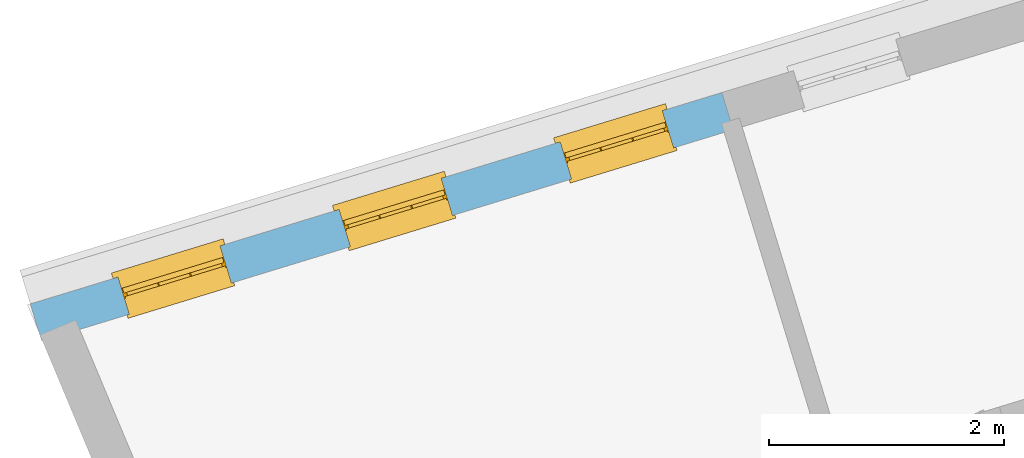
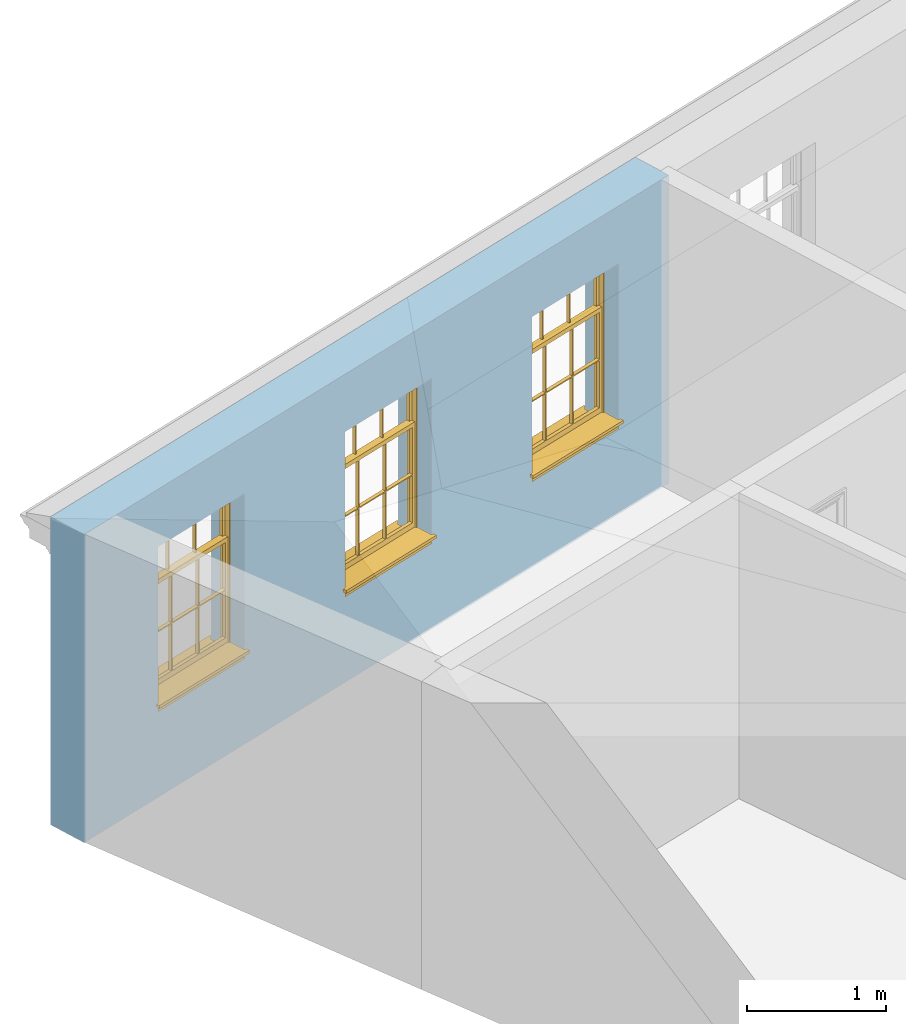
# One storey, part 4 of 10: 3 windows, 3 openings, plus 1 element that does not belong to this part.
"""IFC2X3 building model written with IfcOpenShell, lengths in metres."""

from ifc_helpers import new_model, si_unit, frame, origin, place, context, subcontext, project, spatial, polyline, outline, extrude, faceted_brep, material, layer, layer_set, layer_usage, element, fill, save


model = new_model("IFC2X3")

# Units and contexts
model_context = context("Model", 3, world=origin())
body_context = subcontext(model_context, "Body", "Model", "MODEL_VIEW")
ifc_project = project(units=[si_unit("PLANEANGLEUNIT", "RADIAN"), si_unit("MASSUNIT", "GRAM", prefix="KILO"), si_unit("FORCEUNIT", "NEWTON", prefix="KILO"), si_unit("LENGTHUNIT", "METRE")], contexts=[model_context])

# Site, building, storey
site_placement = place(None, origin())
site = spatial("IfcSite", under=ifc_project, at=site_placement, CompositionType="ELEMENT")
building_placement = place(None, origin())
building = spatial("IfcBuilding", under=site, at=building_placement, Name="Building plot-9", CompositionType="ELEMENT")
storey_placement = place(None, frame((0.0, 0.0, 4.3)))
storey = spatial("IfcBuildingStorey", under=building, at=storey_placement, Name="Floor 1", CompositionType="ELEMENT", Elevation=4.3)

# Wall, openings, windows
ifc_material = material(Name="Masonry")
ifc_layer = layer(ifc_material, 0.33, ventilated=False)
ifc_layer_set = layer_set([ifc_layer], Name="My Wall")
ifc_layer_usage = layer_usage(ifc_layer_set, "AXIS2", "NEGATIVE", 0.08)
wall_placement = place(storey_placement, origin())
wall = element("IfcWallStandardCase", 1, at=wall_placement, inside=storey, material=ifc_layer_usage, Name="exterior", context=body_context, shape_type="SweptSolid", body=[
    extrude(outline(polyline([(34.0704461659636, 21.7289389517045), (33.9739704454548, 22.0445216434864), (28.0907694978616, 20.2459881209039), (28.1872452183703, 19.930405429122), (34.0704461659636, 21.7289389517045)])), origin(), (0.0, 0.0, 1.0), 2.7),
])
opening_1_placement = place(storey_placement, frame((0.0, 0.0, 0.75)))
opening_1 = element("IfcOpeningElement", 2, at=opening_1_placement, cuts=wall, Name="Opening", ObjectType="Opening", context=body_context, shape_type="SweptSolid", body=[
    extrude(outline(polyline([(33.4684048438409, 21.8899668882661), (32.5981616634725, 21.6239277801966), (32.6946373839813, 21.3083450884147), (33.5648805643496, 21.5743841964841), (33.4684048438409, 21.8899668882661)])), origin(), (0.0, 0.0, 1.0), 1.445),
])
opening_2_placement = place(storey_placement, frame((0.0, 0.0, 0.75)))
opening_2 = element("IfcOpeningElement", 3, at=opening_2_placement, cuts=wall, Name="Opening", ObjectType="Opening", context=body_context, shape_type="SweptSolid", body=[
    extrude(outline(polyline([(31.5870304602446, 21.3148182697559), (30.7167872798763, 21.0487791616865), (30.813263000385, 20.7331964699045), (31.6835061807533, 20.999235577974), (31.5870304602446, 21.3148182697559)])), origin(), (0.0, 0.0, 1.0), 1.445),
])
opening_3_placement = place(storey_placement, frame((0.0, 0.0, 0.75)))
opening_3 = element("IfcOpeningElement", 4, at=opening_3_placement, cuts=wall, Name="Opening", ObjectType="Opening", context=body_context, shape_type="SweptSolid", body=[
    extrude(outline(polyline([(29.7056560766483, 20.7396696512458), (28.83541289628, 20.4736305431763), (28.9318886167887, 20.1580478513944), (29.8021317971571, 20.4240869594639), (29.7056560766483, 20.7396696512458)])), origin(), (0.0, 0.0, 1.0), 1.445),
])
window_1_placement = place(storey_placement, frame((33.5414925108929, 21.6508890914616, 0.75), z_axis=(0.0, 0.0, 1.0), x_axis=(-0.870243180368334, -0.266039108069478, 0.0)))
window_1 = element("IfcWindow", 5, at=window_1_placement, inside=storey, Name="bedroom outside window", OverallHeight=1.445, OverallWidth=0.91, context=body_context, shape_type="Brep", held_by="IfcProductRepresentation", body=[
    faceted_brep([(0.876875, -0.105, 0.999097), (0.876875, -0.105, 1.411875), (0.9, -0.105, 1.435), (0.033125, -0.105, 1.411875), (0.033125, -0.105, 0.999097), (0.01, -0.105, 1.435), (0.033125, -0.135, 1.411875), (0.01, -0.135, 1.435), (0.033125, -0.135, 0.999097), (0.876875, -0.135, 1.411875), (0.876875, -0.135, 0.999097), (0.9, -0.135, 1.435), (0.033125, -0.105, 0.960972), (0.01, -0.105, 0.960972), (0.033125, -0.105, 0.548195), (0.876875, -0.105, 0.960972), (0.876875, -0.105, 0.548195), (0.9, -0.105, 0.960972), (0.876875, -0.105, 0.538195), (0.876875, -0.105, 0.125417), (0.9, -0.105, 0.077167), (0.033125, -0.105, 0.125417), (0.033125, -0.105, 0.538195), (0.01, -0.105, 0.077167), (0.9, -0.135, 0.960972), (0.01, -0.135, 0.960972), (-0.0425, -0.25, 0.01), (-0.0425, -0.3, 0.001667), (0.0, -0.25, 0.01), (0.9525, -0.25, 0.01), (0.91, -0.25, 0.01), (0.9525, -0.3, 0.001667), (-0.02, 0.08, 0.077167), (0.0, 0.08, 0.077167), (-0.02, 0.11, 0.077167), (0.0, -0.06, 0.077167), (0.01, -0.06, 0.077167), (0.91, -0.06, 0.077167), (0.91, 0.08, 0.077167), (0.9, -0.06, 0.077167), (0.93, 0.08, 0.077167), (0.93, 0.11, 0.077167), (0.01, -0.105, 0.999097), (0.01, -0.075, 0.999097), (0.9, -0.105, 0.999097), (0.9, -0.075, 0.999097), (0.876875, -0.075, 0.125417), (0.876875, -0.075, 0.538195), (0.9, -0.075, 0.077167), (0.876875, -0.075, 0.548195), (0.876875, -0.075, 0.960972), (0.033125, -0.075, 0.125417), (0.01, -0.075, 0.077167), (0.033125, -0.075, 0.538195), (0.033125, -0.075, 0.960972), (0.033125, -0.075, 0.548195), (-0.02, 0.08, 0.052167), (-0.02, 0.11, 0.052167), (0.93, 0.11, 0.052167), (0.93, 0.08, 0.052167), (0.91, 0.08, 0.052167), (0.0, 0.08, 0.052167), (0.91, -0.15, 0.026667), (0.0, -0.15, 0.026667), (-0.0425, -0.3, -0.123333), (0.9525, -0.3, -0.123333), (-0.0425, -0.25, -0.123333), (0.9525, -0.25, -0.123333), (0.01, -0.06, 1.435), (0.9, -0.06, 1.435), (0.0, -0.06, 1.445), (0.91, -0.06, 1.445), (0.01, -0.15, 0.077167), (0.9, -0.15, 0.077167), (0.592292, -0.105, 0.125417), (0.592292, -0.075, 0.125417), (0.317708, -0.075, 0.125417), (0.317708, -0.105, 0.125417), (0.592292, -0.105, 0.548195), (0.317708, -0.105, 0.548195), (0.317708, -0.105, 0.538195), (0.592292, -0.105, 0.538195), (0.592292, -0.075, 0.548195), (0.317708, -0.075, 0.548195), (0.602292, -0.075, 0.548195), (0.602292, -0.105, 0.548195), (0.317708, -0.075, 0.538195), (0.307708, -0.075, 0.125417), (0.307708, -0.075, 0.538195), (0.602292, -0.075, 0.538195), (0.602292, -0.075, 0.125417), (0.592292, -0.075, 0.538195), (0.307708, -0.075, 0.548195), (0.317708, -0.075, 0.960972), (0.307708, -0.075, 0.960972), (0.602292, -0.075, 0.960972), (0.592292, -0.075, 0.960972), (0.307708, -0.105, 0.538195), (0.307708, -0.105, 0.125417), (0.307708, -0.105, 0.548195), (0.307708, -0.105, 0.960972), (0.592292, -0.105, 0.960972), (0.317708, -0.105, 0.960972), (0.602292, -0.105, 0.960972), (0.602292, -0.105, 0.538195), (0.602292, -0.105, 0.125417), (0.317708, -0.135, 1.411875), (0.307708, -0.135, 1.411875), (0.307708, -0.135, 0.999097), (0.317708, -0.135, 0.999097), (0.602292, -0.135, 1.411875), (0.592292, -0.135, 1.411875), (0.592292, -0.135, 0.999097), (0.602292, -0.135, 0.999097), (0.317708, -0.105, 0.999097), (0.307708, -0.105, 0.999097), (0.307708, -0.105, 1.411875), (0.317708, -0.105, 1.411875), (0.602292, -0.105, 0.999097), (0.592292, -0.105, 0.999097), (0.592292, -0.105, 1.411875), (0.602292, -0.105, 1.411875), (0.91, -0.15, 1.445), (0.9, -0.15, 1.435), (0.01, -0.15, 1.435), (0.0, -0.15, 1.445), (0.91, -0.25, 0.0), (0.0, -0.25, 0.0), (0.91, 0.08, 0.0), (0.0, 0.08, 0.0)], [[[0, 1, 2]], [[3, 4, 5]], [[6, 7, 8]], [[9, 10, 11]], [[12, 13, 14]], [[15, 16, 17]], [[18, 19, 20]], [[21, 22, 23]], [[24, 15, 17]], [[13, 12, 25]], [[26, 27, 28]], [[29, 30, 31]], [[32, 33, 34]], [[35, 36, 33]], [[37, 38, 39]], [[40, 41, 38]], [[42, 4, 43]], [[44, 45, 0]], [[46, 47, 48]], [[49, 50, 45]], [[51, 52, 53]], [[54, 55, 43]], [[38, 33, 36, 39]], [[41, 34, 33, 38]], [[56, 32, 34, 57]], [[57, 34, 41, 58]], [[58, 41, 40, 59]], [[57, 58, 60, 61]], [[52, 48, 39, 36]], [[62, 63, 28, 30]], [[27, 31, 30, 28]], [[27, 64, 65, 31]], [[66, 67, 65, 64]], [[2, 5, 68, 69]], [[68, 70, 71, 69]], [[20, 23, 72, 73]], [[73, 72, 63, 62]], [[74, 75, 76, 77]], [[78, 79, 80, 81]], [[78, 82, 83, 79]], [[16, 49, 84, 85]], [[86, 76, 87, 88]], [[89, 90, 75, 91]], [[92, 88, 53, 55]], [[82, 91, 86, 83]], [[93, 83, 92, 94]], [[95, 84, 82, 96]], [[89, 84, 49, 47]], [[97, 88, 87, 98]], [[22, 53, 88, 97]], [[81, 91, 75, 74]], [[80, 86, 91, 81]], [[77, 76, 86, 80]], [[99, 92, 55, 14]], [[100, 94, 92, 99]], [[101, 96, 82, 78]], [[79, 83, 93, 102]], [[85, 84, 95, 103]], [[104, 89, 47, 18]], [[105, 90, 89, 104]], [[104, 18, 16, 85]], [[80, 97, 98, 77]], [[104, 81, 74, 105]], [[103, 101, 78, 85]], [[99, 14, 22, 97]], [[102, 100, 99, 79]], [[106, 107, 108, 109]], [[110, 111, 112, 113]], [[114, 115, 116, 117]], [[118, 119, 120, 121]], [[107, 116, 115, 108]], [[111, 120, 119, 112]], [[109, 114, 117, 106]], [[113, 118, 121, 110]], [[85, 78, 81, 104]], [[84, 89, 91, 82]], [[83, 86, 88, 92]], [[79, 99, 97, 80]], [[109, 112, 119, 114]], [[102, 93, 96, 101]], [[106, 117, 120, 111]], [[98, 87, 51, 21]], [[6, 3, 116, 107]], [[110, 121, 1, 9]], [[19, 46, 90, 105]], [[26, 66, 64, 27]], [[29, 31, 65, 67]], [[25, 24, 112, 109]], [[11, 7, 106, 111]], [[75, 48, 52, 76]], [[43, 45, 96, 93]], [[45, 43, 114, 119]], [[5, 2, 120, 117]], [[24, 25, 102, 101]], [[42, 5, 4]], [[2, 44, 0]], [[49, 45, 48, 47]], [[52, 43, 55, 53]], [[14, 13, 23, 22]], [[20, 17, 16, 18]], [[24, 11, 10]], [[25, 8, 7]], [[8, 4, 3, 6]], [[9, 1, 0, 10]], [[15, 50, 49, 16]], [[18, 47, 46, 19]], [[21, 51, 53, 22]], [[14, 55, 54, 12]], [[44, 2, 69, 45]], [[68, 5, 42, 43]], [[36, 35, 70, 68]], [[39, 69, 71, 37]], [[62, 122, 123, 73]], [[63, 72, 124, 125]], [[8, 108, 115, 4]], [[113, 10, 0, 118]], [[94, 100, 12, 54]], [[17, 20, 73, 24]], [[72, 23, 13, 25]], [[52, 36, 68, 43]], [[69, 39, 48, 45]], [[11, 24, 73, 123]], [[7, 124, 72, 25]], [[23, 77, 98]], [[98, 21, 23]], [[105, 74, 20]], [[20, 19, 105]], [[20, 74, 77, 23]], [[113, 112, 24]], [[24, 10, 113]], [[25, 109, 108]], [[108, 8, 25]], [[110, 9, 11]], [[11, 111, 110]], [[7, 6, 107]], [[107, 106, 7]], [[5, 117, 116]], [[116, 3, 5]], [[121, 120, 2]], [[2, 1, 121]], [[11, 123, 124, 7]], [[122, 125, 124, 123]], [[43, 93, 94]], [[94, 54, 43]], [[96, 45, 95]], [[50, 95, 45]], [[15, 103, 95, 50]], [[48, 75, 90]], [[90, 46, 48]], [[87, 76, 52]], [[52, 51, 87]], [[103, 15, 24]], [[24, 101, 103]], [[100, 102, 25]], [[25, 12, 100]], [[115, 114, 43]], [[43, 4, 115]], [[118, 0, 45]], [[45, 119, 118]], [[71, 70, 125, 122]], [[70, 35, 63, 125]], [[122, 62, 37, 71]], [[126, 67, 66, 127]], [[60, 58, 59]], [[38, 60, 59, 40]], [[61, 56, 57]], [[32, 56, 61, 33]], [[61, 60, 128, 129]], [[62, 60, 38, 37]], [[126, 128, 60, 62]], [[33, 61, 63, 35]], [[61, 129, 127, 63]], [[128, 126, 127, 129]], [[28, 127, 66, 26]], [[63, 127, 28]], [[29, 67, 126, 30]], [[30, 126, 62]]]),
])
fill(opening_1, window_1)
window_2_placement = place(storey_placement, frame((31.6601181272967, 21.0757404729514, 0.75), z_axis=(0.0, 0.0, 1.0), x_axis=(-0.870243180368337, -0.266039108069474, 0.0)))
window_2 = element("IfcWindow", 6, at=window_2_placement, inside=storey, Name="bedroom outside window", OverallHeight=1.445, OverallWidth=0.91, context=body_context, shape_type="Brep", held_by="IfcProductRepresentation", body=[
    faceted_brep([(0.876875, -0.105, 0.999097), (0.876875, -0.105, 1.411875), (0.9, -0.105, 1.435), (0.033125, -0.105, 1.411875), (0.033125, -0.105, 0.999097), (0.01, -0.105, 1.435), (0.033125, -0.135, 1.411875), (0.01, -0.135, 1.435), (0.033125, -0.135, 0.999097), (0.876875, -0.135, 1.411875), (0.876875, -0.135, 0.999097), (0.9, -0.135, 1.435), (0.033125, -0.105, 0.960972), (0.01, -0.105, 0.960972), (0.033125, -0.105, 0.548195), (0.876875, -0.105, 0.960972), (0.876875, -0.105, 0.548195), (0.9, -0.105, 0.960972), (0.876875, -0.105, 0.538195), (0.876875, -0.105, 0.125417), (0.9, -0.105, 0.077167), (0.033125, -0.105, 0.125417), (0.033125, -0.105, 0.538195), (0.01, -0.105, 0.077167), (0.9, -0.135, 0.960972), (0.01, -0.135, 0.960972), (-0.0425, -0.25, 0.01), (-0.0425, -0.3, 0.001667), (0.0, -0.25, 0.01), (0.9525, -0.25, 0.01), (0.91, -0.25, 0.01), (0.9525, -0.3, 0.001667), (-0.02, 0.08, 0.077167), (0.0, 0.08, 0.077167), (-0.02, 0.11, 0.077167), (0.0, -0.06, 0.077167), (0.01, -0.06, 0.077167), (0.91, -0.06, 0.077167), (0.91, 0.08, 0.077167), (0.9, -0.06, 0.077167), (0.93, 0.08, 0.077167), (0.93, 0.11, 0.077167), (0.01, -0.105, 0.999097), (0.01, -0.075, 0.999097), (0.9, -0.105, 0.999097), (0.9, -0.075, 0.999097), (0.876875, -0.075, 0.125417), (0.876875, -0.075, 0.538195), (0.9, -0.075, 0.077167), (0.876875, -0.075, 0.548195), (0.876875, -0.075, 0.960972), (0.033125, -0.075, 0.125417), (0.01, -0.075, 0.077167), (0.033125, -0.075, 0.538195), (0.033125, -0.075, 0.960972), (0.033125, -0.075, 0.548195), (-0.02, 0.08, 0.052167), (-0.02, 0.11, 0.052167), (0.93, 0.11, 0.052167), (0.93, 0.08, 0.052167), (0.91, 0.08, 0.052167), (0.0, 0.08, 0.052167), (0.91, -0.15, 0.026667), (0.0, -0.15, 0.026667), (-0.0425, -0.3, -0.123333), (0.9525, -0.3, -0.123333), (-0.0425, -0.25, -0.123333), (0.9525, -0.25, -0.123333), (0.01, -0.06, 1.435), (0.9, -0.06, 1.435), (0.0, -0.06, 1.445), (0.91, -0.06, 1.445), (0.01, -0.15, 0.077167), (0.9, -0.15, 0.077167), (0.592292, -0.105, 0.125417), (0.592292, -0.075, 0.125417), (0.317708, -0.075, 0.125417), (0.317708, -0.105, 0.125417), (0.592292, -0.105, 0.548195), (0.317708, -0.105, 0.548195), (0.317708, -0.105, 0.538195), (0.592292, -0.105, 0.538195), (0.592292, -0.075, 0.548195), (0.317708, -0.075, 0.548195), (0.602292, -0.075, 0.548195), (0.602292, -0.105, 0.548195), (0.317708, -0.075, 0.538195), (0.307708, -0.075, 0.125417), (0.307708, -0.075, 0.538195), (0.602292, -0.075, 0.538195), (0.602292, -0.075, 0.125417), (0.592292, -0.075, 0.538195), (0.307708, -0.075, 0.548195), (0.317708, -0.075, 0.960972), (0.307708, -0.075, 0.960972), (0.602292, -0.075, 0.960972), (0.592292, -0.075, 0.960972), (0.307708, -0.105, 0.538195), (0.307708, -0.105, 0.125417), (0.307708, -0.105, 0.548195), (0.307708, -0.105, 0.960972), (0.592292, -0.105, 0.960972), (0.317708, -0.105, 0.960972), (0.602292, -0.105, 0.960972), (0.602292, -0.105, 0.538195), (0.602292, -0.105, 0.125417), (0.317708, -0.135, 1.411875), (0.307708, -0.135, 1.411875), (0.307708, -0.135, 0.999097), (0.317708, -0.135, 0.999097), (0.602292, -0.135, 1.411875), (0.592292, -0.135, 1.411875), (0.592292, -0.135, 0.999097), (0.602292, -0.135, 0.999097), (0.317708, -0.105, 0.999097), (0.307708, -0.105, 0.999097), (0.307708, -0.105, 1.411875), (0.317708, -0.105, 1.411875), (0.602292, -0.105, 0.999097), (0.592292, -0.105, 0.999097), (0.592292, -0.105, 1.411875), (0.602292, -0.105, 1.411875), (0.91, -0.15, 1.445), (0.9, -0.15, 1.435), (0.01, -0.15, 1.435), (0.0, -0.15, 1.445), (0.91, -0.25, 0.0), (0.0, -0.25, 0.0), (0.91, 0.08, 0.0), (0.0, 0.08, 0.0)], [[[0, 1, 2]], [[3, 4, 5]], [[6, 7, 8]], [[9, 10, 11]], [[12, 13, 14]], [[15, 16, 17]], [[18, 19, 20]], [[21, 22, 23]], [[24, 15, 17]], [[13, 12, 25]], [[26, 27, 28]], [[29, 30, 31]], [[32, 33, 34]], [[35, 36, 33]], [[37, 38, 39]], [[40, 41, 38]], [[42, 4, 43]], [[44, 45, 0]], [[46, 47, 48]], [[49, 50, 45]], [[51, 52, 53]], [[54, 55, 43]], [[38, 33, 36, 39]], [[41, 34, 33, 38]], [[56, 32, 34, 57]], [[57, 34, 41, 58]], [[58, 41, 40, 59]], [[57, 58, 60, 61]], [[52, 48, 39, 36]], [[62, 63, 28, 30]], [[27, 31, 30, 28]], [[27, 64, 65, 31]], [[66, 67, 65, 64]], [[2, 5, 68, 69]], [[68, 70, 71, 69]], [[20, 23, 72, 73]], [[73, 72, 63, 62]], [[74, 75, 76, 77]], [[78, 79, 80, 81]], [[78, 82, 83, 79]], [[16, 49, 84, 85]], [[86, 76, 87, 88]], [[89, 90, 75, 91]], [[92, 88, 53, 55]], [[82, 91, 86, 83]], [[93, 83, 92, 94]], [[95, 84, 82, 96]], [[89, 84, 49, 47]], [[97, 88, 87, 98]], [[22, 53, 88, 97]], [[81, 91, 75, 74]], [[80, 86, 91, 81]], [[77, 76, 86, 80]], [[99, 92, 55, 14]], [[100, 94, 92, 99]], [[101, 96, 82, 78]], [[79, 83, 93, 102]], [[85, 84, 95, 103]], [[104, 89, 47, 18]], [[105, 90, 89, 104]], [[104, 18, 16, 85]], [[80, 97, 98, 77]], [[104, 81, 74, 105]], [[103, 101, 78, 85]], [[99, 14, 22, 97]], [[102, 100, 99, 79]], [[106, 107, 108, 109]], [[110, 111, 112, 113]], [[114, 115, 116, 117]], [[118, 119, 120, 121]], [[107, 116, 115, 108]], [[111, 120, 119, 112]], [[109, 114, 117, 106]], [[113, 118, 121, 110]], [[85, 78, 81, 104]], [[84, 89, 91, 82]], [[83, 86, 88, 92]], [[79, 99, 97, 80]], [[109, 112, 119, 114]], [[102, 93, 96, 101]], [[106, 117, 120, 111]], [[98, 87, 51, 21]], [[6, 3, 116, 107]], [[110, 121, 1, 9]], [[19, 46, 90, 105]], [[26, 66, 64, 27]], [[29, 31, 65, 67]], [[25, 24, 112, 109]], [[11, 7, 106, 111]], [[75, 48, 52, 76]], [[43, 45, 96, 93]], [[45, 43, 114, 119]], [[5, 2, 120, 117]], [[24, 25, 102, 101]], [[42, 5, 4]], [[2, 44, 0]], [[49, 45, 48, 47]], [[52, 43, 55, 53]], [[14, 13, 23, 22]], [[20, 17, 16, 18]], [[24, 11, 10]], [[25, 8, 7]], [[8, 4, 3, 6]], [[9, 1, 0, 10]], [[15, 50, 49, 16]], [[18, 47, 46, 19]], [[21, 51, 53, 22]], [[14, 55, 54, 12]], [[44, 2, 69, 45]], [[68, 5, 42, 43]], [[36, 35, 70, 68]], [[39, 69, 71, 37]], [[62, 122, 123, 73]], [[63, 72, 124, 125]], [[8, 108, 115, 4]], [[113, 10, 0, 118]], [[94, 100, 12, 54]], [[17, 20, 73, 24]], [[72, 23, 13, 25]], [[52, 36, 68, 43]], [[69, 39, 48, 45]], [[11, 24, 73, 123]], [[7, 124, 72, 25]], [[23, 77, 98]], [[98, 21, 23]], [[105, 74, 20]], [[20, 19, 105]], [[20, 74, 77, 23]], [[113, 112, 24]], [[24, 10, 113]], [[25, 109, 108]], [[108, 8, 25]], [[110, 9, 11]], [[11, 111, 110]], [[7, 6, 107]], [[107, 106, 7]], [[5, 117, 116]], [[116, 3, 5]], [[121, 120, 2]], [[2, 1, 121]], [[11, 123, 124, 7]], [[122, 125, 124, 123]], [[43, 93, 94]], [[94, 54, 43]], [[96, 45, 95]], [[50, 95, 45]], [[15, 103, 95, 50]], [[48, 75, 90]], [[90, 46, 48]], [[87, 76, 52]], [[52, 51, 87]], [[103, 15, 24]], [[24, 101, 103]], [[100, 102, 25]], [[25, 12, 100]], [[115, 114, 43]], [[43, 4, 115]], [[118, 0, 45]], [[45, 119, 118]], [[71, 70, 125, 122]], [[70, 35, 63, 125]], [[122, 62, 37, 71]], [[126, 67, 66, 127]], [[60, 58, 59]], [[38, 60, 59, 40]], [[61, 56, 57]], [[32, 56, 61, 33]], [[61, 60, 128, 129]], [[62, 60, 38, 37]], [[126, 128, 60, 62]], [[33, 61, 63, 35]], [[61, 129, 127, 63]], [[128, 126, 127, 129]], [[28, 127, 66, 26]], [[63, 127, 28]], [[29, 67, 126, 30]], [[30, 126, 62]]]),
])
fill(opening_2, window_2)
window_3_placement = place(storey_placement, frame((29.7787437437004, 20.5005918544413, 0.75), z_axis=(0.0, 0.0, 1.0), x_axis=(-0.870243180368337, -0.266039108069478, 0.0)))
window_3 = element("IfcWindow", 7, at=window_3_placement, inside=storey, Name="bedroom outside window", OverallHeight=1.445, OverallWidth=0.91, context=body_context, shape_type="Brep", held_by="IfcProductRepresentation", body=[
    faceted_brep([(0.876875, -0.105, 0.999097), (0.876875, -0.105, 1.411875), (0.9, -0.105, 1.435), (0.033125, -0.105, 1.411875), (0.033125, -0.105, 0.999097), (0.01, -0.105, 1.435), (0.033125, -0.135, 1.411875), (0.01, -0.135, 1.435), (0.033125, -0.135, 0.999097), (0.876875, -0.135, 1.411875), (0.876875, -0.135, 0.999097), (0.9, -0.135, 1.435), (0.033125, -0.105, 0.960972), (0.01, -0.105, 0.960972), (0.033125, -0.105, 0.548195), (0.876875, -0.105, 0.960972), (0.876875, -0.105, 0.548195), (0.9, -0.105, 0.960972), (0.876875, -0.105, 0.538195), (0.876875, -0.105, 0.125417), (0.9, -0.105, 0.077167), (0.033125, -0.105, 0.125417), (0.033125, -0.105, 0.538195), (0.01, -0.105, 0.077167), (0.9, -0.135, 0.960972), (0.01, -0.135, 0.960972), (-0.0425, -0.25, 0.01), (-0.0425, -0.3, 0.001667), (0.0, -0.25, 0.01), (0.9525, -0.25, 0.01), (0.91, -0.25, 0.01), (0.9525, -0.3, 0.001667), (-0.02, 0.08, 0.077167), (0.0, 0.08, 0.077167), (-0.02, 0.11, 0.077167), (0.0, -0.06, 0.077167), (0.01, -0.06, 0.077167), (0.91, -0.06, 0.077167), (0.91, 0.08, 0.077167), (0.9, -0.06, 0.077167), (0.93, 0.08, 0.077167), (0.93, 0.11, 0.077167), (0.01, -0.105, 0.999097), (0.01, -0.075, 0.999097), (0.9, -0.105, 0.999097), (0.9, -0.075, 0.999097), (0.876875, -0.075, 0.125417), (0.876875, -0.075, 0.538195), (0.9, -0.075, 0.077167), (0.876875, -0.075, 0.548195), (0.876875, -0.075, 0.960972), (0.033125, -0.075, 0.125417), (0.01, -0.075, 0.077167), (0.033125, -0.075, 0.538195), (0.033125, -0.075, 0.960972), (0.033125, -0.075, 0.548195), (-0.02, 0.08, 0.052167), (-0.02, 0.11, 0.052167), (0.93, 0.11, 0.052167), (0.93, 0.08, 0.052167), (0.91, 0.08, 0.052167), (0.0, 0.08, 0.052167), (0.91, -0.15, 0.026667), (0.0, -0.15, 0.026667), (-0.0425, -0.3, -0.123333), (0.9525, -0.3, -0.123333), (-0.0425, -0.25, -0.123333), (0.9525, -0.25, -0.123333), (0.01, -0.06, 1.435), (0.9, -0.06, 1.435), (0.0, -0.06, 1.445), (0.91, -0.06, 1.445), (0.01, -0.15, 0.077167), (0.9, -0.15, 0.077167), (0.592292, -0.105, 0.125417), (0.592292, -0.075, 0.125417), (0.317708, -0.075, 0.125417), (0.317708, -0.105, 0.125417), (0.592292, -0.105, 0.548195), (0.317708, -0.105, 0.548195), (0.317708, -0.105, 0.538195), (0.592292, -0.105, 0.538195), (0.592292, -0.075, 0.548195), (0.317708, -0.075, 0.548195), (0.602292, -0.075, 0.548195), (0.602292, -0.105, 0.548195), (0.317708, -0.075, 0.538195), (0.307708, -0.075, 0.125417), (0.307708, -0.075, 0.538195), (0.602292, -0.075, 0.538195), (0.602292, -0.075, 0.125417), (0.592292, -0.075, 0.538195), (0.307708, -0.075, 0.548195), (0.317708, -0.075, 0.960972), (0.307708, -0.075, 0.960972), (0.602292, -0.075, 0.960972), (0.592292, -0.075, 0.960972), (0.307708, -0.105, 0.538195), (0.307708, -0.105, 0.125417), (0.307708, -0.105, 0.548195), (0.307708, -0.105, 0.960972), (0.592292, -0.105, 0.960972), (0.317708, -0.105, 0.960972), (0.602292, -0.105, 0.960972), (0.602292, -0.105, 0.538195), (0.602292, -0.105, 0.125417), (0.317708, -0.135, 1.411875), (0.307708, -0.135, 1.411875), (0.307708, -0.135, 0.999097), (0.317708, -0.135, 0.999097), (0.602292, -0.135, 1.411875), (0.592292, -0.135, 1.411875), (0.592292, -0.135, 0.999097), (0.602292, -0.135, 0.999097), (0.317708, -0.105, 0.999097), (0.307708, -0.105, 0.999097), (0.307708, -0.105, 1.411875), (0.317708, -0.105, 1.411875), (0.602292, -0.105, 0.999097), (0.592292, -0.105, 0.999097), (0.592292, -0.105, 1.411875), (0.602292, -0.105, 1.411875), (0.91, -0.15, 1.445), (0.9, -0.15, 1.435), (0.01, -0.15, 1.435), (0.0, -0.15, 1.445), (0.91, -0.25, 0.0), (0.0, -0.25, 0.0), (0.91, 0.08, 0.0), (0.0, 0.08, 0.0)], [[[0, 1, 2]], [[3, 4, 5]], [[6, 7, 8]], [[9, 10, 11]], [[12, 13, 14]], [[15, 16, 17]], [[18, 19, 20]], [[21, 22, 23]], [[24, 15, 17]], [[13, 12, 25]], [[26, 27, 28]], [[29, 30, 31]], [[32, 33, 34]], [[35, 36, 33]], [[37, 38, 39]], [[40, 41, 38]], [[42, 4, 43]], [[44, 45, 0]], [[46, 47, 48]], [[49, 50, 45]], [[51, 52, 53]], [[54, 55, 43]], [[38, 33, 36, 39]], [[41, 34, 33, 38]], [[56, 32, 34, 57]], [[57, 34, 41, 58]], [[58, 41, 40, 59]], [[57, 58, 60, 61]], [[52, 48, 39, 36]], [[62, 63, 28, 30]], [[27, 31, 30, 28]], [[27, 64, 65, 31]], [[66, 67, 65, 64]], [[2, 5, 68, 69]], [[68, 70, 71, 69]], [[20, 23, 72, 73]], [[73, 72, 63, 62]], [[74, 75, 76, 77]], [[78, 79, 80, 81]], [[78, 82, 83, 79]], [[16, 49, 84, 85]], [[86, 76, 87, 88]], [[89, 90, 75, 91]], [[92, 88, 53, 55]], [[82, 91, 86, 83]], [[93, 83, 92, 94]], [[95, 84, 82, 96]], [[89, 84, 49, 47]], [[97, 88, 87, 98]], [[22, 53, 88, 97]], [[81, 91, 75, 74]], [[80, 86, 91, 81]], [[77, 76, 86, 80]], [[99, 92, 55, 14]], [[100, 94, 92, 99]], [[101, 96, 82, 78]], [[79, 83, 93, 102]], [[85, 84, 95, 103]], [[104, 89, 47, 18]], [[105, 90, 89, 104]], [[104, 18, 16, 85]], [[80, 97, 98, 77]], [[104, 81, 74, 105]], [[103, 101, 78, 85]], [[99, 14, 22, 97]], [[102, 100, 99, 79]], [[106, 107, 108, 109]], [[110, 111, 112, 113]], [[114, 115, 116, 117]], [[118, 119, 120, 121]], [[107, 116, 115, 108]], [[111, 120, 119, 112]], [[109, 114, 117, 106]], [[113, 118, 121, 110]], [[85, 78, 81, 104]], [[84, 89, 91, 82]], [[83, 86, 88, 92]], [[79, 99, 97, 80]], [[109, 112, 119, 114]], [[102, 93, 96, 101]], [[106, 117, 120, 111]], [[98, 87, 51, 21]], [[6, 3, 116, 107]], [[110, 121, 1, 9]], [[19, 46, 90, 105]], [[26, 66, 64, 27]], [[29, 31, 65, 67]], [[25, 24, 112, 109]], [[11, 7, 106, 111]], [[75, 48, 52, 76]], [[43, 45, 96, 93]], [[45, 43, 114, 119]], [[5, 2, 120, 117]], [[24, 25, 102, 101]], [[42, 5, 4]], [[2, 44, 0]], [[49, 45, 48, 47]], [[52, 43, 55, 53]], [[14, 13, 23, 22]], [[20, 17, 16, 18]], [[24, 11, 10]], [[25, 8, 7]], [[8, 4, 3, 6]], [[9, 1, 0, 10]], [[15, 50, 49, 16]], [[18, 47, 46, 19]], [[21, 51, 53, 22]], [[14, 55, 54, 12]], [[44, 2, 69, 45]], [[68, 5, 42, 43]], [[36, 35, 70, 68]], [[39, 69, 71, 37]], [[62, 122, 123, 73]], [[63, 72, 124, 125]], [[8, 108, 115, 4]], [[113, 10, 0, 118]], [[94, 100, 12, 54]], [[17, 20, 73, 24]], [[72, 23, 13, 25]], [[52, 36, 68, 43]], [[69, 39, 48, 45]], [[11, 24, 73, 123]], [[7, 124, 72, 25]], [[23, 77, 98]], [[98, 21, 23]], [[105, 74, 20]], [[20, 19, 105]], [[20, 74, 77, 23]], [[113, 112, 24]], [[24, 10, 113]], [[25, 109, 108]], [[108, 8, 25]], [[110, 9, 11]], [[11, 111, 110]], [[7, 6, 107]], [[107, 106, 7]], [[5, 117, 116]], [[116, 3, 5]], [[121, 120, 2]], [[2, 1, 121]], [[11, 123, 124, 7]], [[122, 125, 124, 123]], [[43, 93, 94]], [[94, 54, 43]], [[96, 45, 95]], [[50, 95, 45]], [[15, 103, 95, 50]], [[48, 75, 90]], [[90, 46, 48]], [[87, 76, 52]], [[52, 51, 87]], [[103, 15, 24]], [[24, 101, 103]], [[100, 102, 25]], [[25, 12, 100]], [[115, 114, 43]], [[43, 4, 115]], [[118, 0, 45]], [[45, 119, 118]], [[71, 70, 125, 122]], [[70, 35, 63, 125]], [[122, 62, 37, 71]], [[126, 67, 66, 127]], [[60, 58, 59]], [[38, 60, 59, 40]], [[61, 56, 57]], [[32, 56, 61, 33]], [[61, 60, 128, 129]], [[62, 60, 38, 37]], [[126, 128, 60, 62]], [[33, 61, 63, 35]], [[61, 129, 127, 63]], [[128, 126, 127, 129]], [[28, 127, 66, 26]], [[63, 127, 28]], [[29, 67, 126, 30]], [[30, 126, 62]]]),
])
fill(opening_3, window_3)

save(model, "model.ifc")
